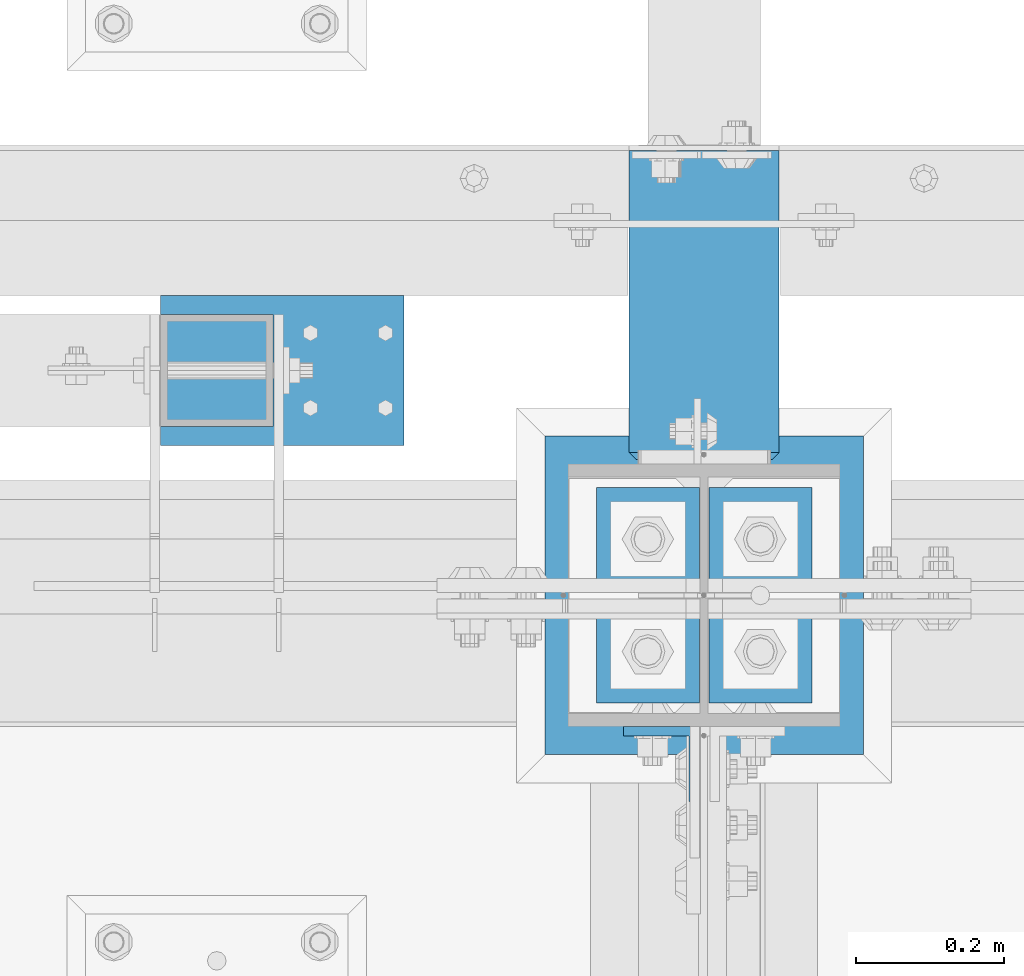
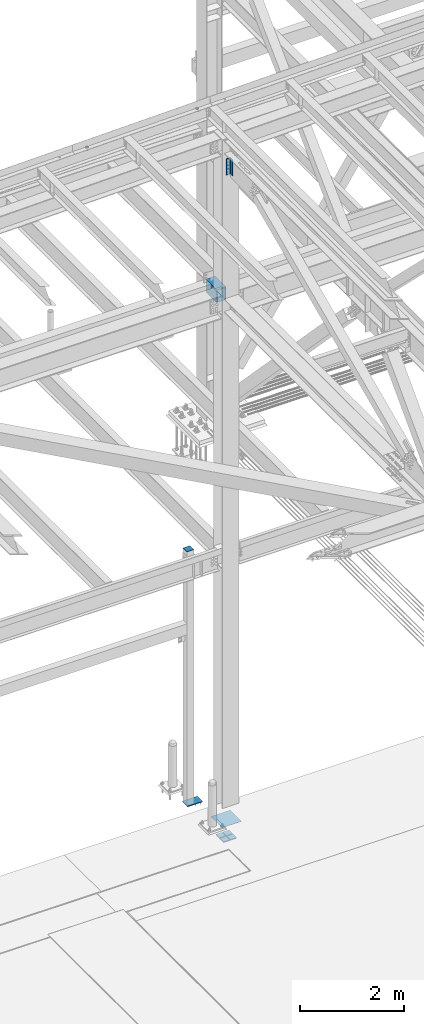
# One storey, part 2544 of 3843: 9 beams, 4 elements without a shape of their own.
"""IFC2X3 building model written with IfcOpenShell, lengths in millimetres."""

from ifc_helpers import new_model, si_unit, frame, origin_with_axes, place, context, subcontext, project, spatial, faceted_brep, material, type_object, element, aggregate, save


model = new_model("IFC2X3")

# Units and contexts
model_context = context("Model", 3, precision=1e-05, world=origin_with_axes())
body_context = subcontext(model_context, "Body", "Model", "MODEL_VIEW")
ifc_project = project(units=[si_unit("LENGTHUNIT", "METRE", prefix="MILLI"), si_unit("AREAUNIT", "SQUARE_METRE"), si_unit("VOLUMEUNIT", "CUBIC_METRE"), si_unit("MASSUNIT", "GRAM", prefix="KILO"), si_unit("TIMEUNIT", "SECOND"), si_unit("PLANEANGLEUNIT", "RADIAN"), si_unit("SOLIDANGLEUNIT", "STERADIAN"), si_unit("THERMODYNAMICTEMPERATUREUNIT", "DEGREE_CELSIUS"), si_unit("LUMINOUSINTENSITYUNIT", "LUMEN")], contexts=[model_context])

# Site, building, storey
site_placement = place(None, origin_with_axes())
site = spatial("IfcSite", under=ifc_project, at=site_placement, CompositionType="ELEMENT")
building_placement = place(site_placement, origin_with_axes())
building = spatial("IfcBuilding", under=site, at=building_placement, Name="Undefined", CompositionType="ELEMENT")
storey_placement = place(building_placement, origin_with_axes())
storey = spatial("IfcBuildingStorey", under=building, at=storey_placement, Name="Undefined", CompositionType="ELEMENT", Elevation=0.0)

# Assembly, beam
assembly_1_placement = place(storey_placement, origin_with_axes())
assembly_1 = element("IfcElementAssembly", 1, at=assembly_1_placement, inside=storey, Name="PLATE", AssemblyPlace="NOTDEFINED", PredefinedType="RIGID_FRAME")
ifc_material_1 = material(Name="STEEL/A572-50")
beam_type_1 = type_object("IfcBeamType", Name="L4X4X1/2", PredefinedType="NOTDEFINED")
beam_1_placement = place(assembly_1_placement, frame((70197.6625, 91986.0999999455, 45662.9621203218), z_axis=(0.0, -1.0, 0.0), x_axis=(0.0, 0.0, -1.0)))
beam_1 = element("IfcBeam", 2, at=beam_1_placement, type_object=beam_type_1, material=ifc_material_1, Name="ANGLE", ObjectType="L4X4X1/2", context=body_context, shape_type="Brep", body=[
    faceted_brep([(0.0, 50.8000000000029, -50.8000000000029), (0.0, 50.8000000000029, 50.8000000000029), (381.0, 50.8000000000029, 50.8000000000029), (381.0, 50.8000000000029, -50.8000000000029), (0.0, 38.0999999999985, 50.8000000000029), (381.0, 38.0999999999985, 50.8000000000029), (0.0, 38.0999999999985, -38.0999999999985), (381.0, 38.0999999999985, -38.1000000000058), (0.0, -50.8000000000029, -38.1000000000058), (381.0, -50.8000000000029, -38.1000000000058), (0.0, -50.8000000000029, -50.8000000000029), (381.0, -50.8000000000029, -50.8000000000029)], [[[0, 1, 2, 3]], [[1, 4, 5, 2]], [[4, 6, 7, 5]], [[6, 8, 9, 7]], [[8, 10, 11, 9]], [[10, 0, 3, 11]], [[5, 7, 9, 11, 3, 2]], [[10, 8, 6, 4, 1, 0]]]),
])
aggregate(assembly_1, [beam_1])

assembly_2_placement = place(storey_placement, origin_with_axes())
assembly_2 = element("IfcElementAssembly", 3, at=assembly_2_placement, inside=storey, Name="POST", AssemblyPlace="NOTDEFINED", PredefinedType="RIGID_FRAME")
beam_type_2 = type_object("IfcBeamType", PredefinedType="NOTDEFINED")
beam_2_placement = place(assembly_2_placement, frame((69596.0, 92443.3, 36433.125), z_axis=(1.0, 0.0, 0.0), x_axis=(0.0, 1.0, 0.0)))
beam_2 = element("IfcBeam", 4, at=beam_2_placement, type_object=beam_type_2, material=ifc_material_1, Name="PLATE", context=body_context, shape_type="Brep", body=[
    faceted_brep([(0.0, 3.17500000000291, -76.2000000000007), (0.0, 3.17499999999927, 76.1999969482422), (152.399999999994, 3.17500000000291, 76.1999999999971), (152.399999999994, 3.17500000000291, -76.1999999999971), (0.0, -3.17499999999927, 76.1999969482422), (152.399999999994, -3.17500000000291, 76.1999999999971), (0.0, -3.17500000000291, -76.2000000000007), (152.399999999994, -3.17500000000291, -76.1999999999971)], [[[0, 1, 2, 3]], [[1, 4, 5, 2]], [[4, 6, 7, 5]], [[6, 0, 3, 7]], [[5, 7, 3, 2]], [[6, 4, 1, 0]]]),
])

assembly_3_placement = place(storey_placement, origin_with_axes())
assembly_3 = element("IfcElementAssembly", 5, at=assembly_3_placement, inside=storey, Name="COLUMN", AssemblyPlace="NOTDEFINED", PredefinedType="RIGID_FRAME")
ifc_material_2 = material()
beam_type_3 = type_object("IfcBeamType", Name="HSS12X8X3/8", PredefinedType="NOTDEFINED")
beam_3_placement = place(assembly_3_placement, frame((70256.4, 92392.5, 42214.8), z_axis=(0.0, 0.0, 1.0), x_axis=(0.0, 1.0, 0.0)))
beam_3 = element("IfcBeam", 6, at=beam_3_placement, type_object=beam_type_3, material=ifc_material_2, Name="GIRT", ObjectType="HSS12X8X3/8", context=body_context, shape_type="Brep", body=[
    faceted_brep([(15.8750001309381, 101.600000000006, 152.399999999972), (15.8749984899478, 101.600000000006, -152.400000000031), (6.35000000002037, 92.0749999999971, -142.875), (6.35000000002037, 92.0749999999971, 142.875), (15.8749984899478, -101.600000000006, -152.400000000031), (6.35000000002037, -92.0749999999971, -142.875), (15.8750001044536, -101.600000052975, 152.399999973481), (6.35000000002037, -92.0749999999971, 142.875), (425.449999999983, -101.600000000006, 152.400000000001), (425.449999999983, 101.600000000006, 152.400000000001), (425.449999999983, -101.600000000006, -152.400000000001), (425.449999999983, 101.600000000006, -152.400000000001), (425.449999999957, -92.074999999968, 142.874999999971), (425.450000000015, 92.0749999999971, 142.875), (425.450000000015, 92.0749999999971, -142.875), (425.450000000015, -92.0749999999971, -142.875)], [[[0, 1, 2, 3]], [[4, 5, 2, 1]], [[6, 7, 5, 4]], [[8, 9, 0, 6]], [[10, 8, 6, 4]], [[11, 10, 4, 1]], [[9, 11, 1, 0]], [[8, 10, 11, 9], [12, 13, 14, 15]], [[3, 2, 14, 13]], [[2, 5, 15, 14]], [[5, 7, 12, 15]], [[7, 3, 13, 12]], [[0, 3, 7, 6]]]),
])
aggregate(assembly_3, [beam_3])

# Beam
beam_type_4 = type_object("IfcBeamType", PredefinedType="NOTDEFINED")
beam_4_placement = place(assembly_2_placement, frame((69684.9000015259, 92417.9000003815, 30486.35), z_axis=(-1.0, 0.0, 0.0), x_axis=(0.0, 1.0, 0.0)))
beam_4 = element("IfcBeam", 7, at=beam_4_placement, type_object=beam_type_4, material=ifc_material_1, context=body_context, shape_type="Brep", body=[
    faceted_brep([(-4.07453626394272e-10, 6.34999999999854, -165.099999999366), (3.92901711165905e-10, 6.34999999999854, 165.099999999351), (203.199999237055, 6.34999999999854, 165.099999999999), (203.199999237055, 6.34999999999854, -165.099999999999), (3.92901711165905e-10, -6.34999999999854, 165.099999999351), (203.199999237055, -6.34999999999854, 165.099999999999), (-4.07453626394272e-10, -6.34999999999854, -165.099999999366), (203.199999237055, -6.34999999999854, -165.099999999999)], [[[0, 1, 2, 3]], [[1, 4, 5, 2]], [[4, 6, 7, 5]], [[6, 0, 3, 7]], [[5, 7, 3, 2]], [[6, 4, 1, 0]]]),
])

aggregate(assembly_2, [beam_2, beam_4])

# Assembly, beams
assembly_4_placement = place(storey_placement, origin_with_axes())
assembly_4 = element("IfcElementAssembly", 8, at=assembly_4_placement, inside=storey, Name="TEMPLATE", AssemblyPlace="NOTDEFINED", PredefinedType="RIGID_FRAME")
beam_type_5 = type_object("IfcBeamType", PredefinedType="NOTDEFINED")
beam_5_placement = place(assembly_4_placement, frame((70180.2, 92068.65, 29656.0875), z_axis=(1.0, 0.0, 0.0), x_axis=(0.0, 1.0, 0.0)))
beam_5 = element("IfcBeam", 9, at=beam_5_placement, type_object=beam_type_5, material=ifc_material_1, context=body_context, shape_type="Brep", body=[
    faceted_brep([(0.0, 11.1124999999993, -69.8499999999985), (0.0, 11.1124999999993, 69.8499999999985), (139.699999999997, 11.1124999999993, 69.8499999999985), (139.699999999997, 11.1124999999993, -69.8499999999985), (0.0, -11.1124999999993, 69.8499999999985), (139.699999999997, -11.1124999999993, 69.8499999999985), (0.0, -11.1124999999993, -69.8499999999985), (139.699999999997, -11.1124999999993, -69.8499999999985)], [[[0, 1, 2, 3]], [[1, 4, 5, 2]], [[4, 6, 7, 5]], [[6, 0, 3, 7]], [[5, 7, 3, 2]], [[6, 4, 1, 0]]]),
])
beam_6_placement = place(assembly_4_placement, frame((70332.6, 92068.65, 29656.0875), z_axis=(1.0, 0.0, 0.0), x_axis=(0.0, 1.0, 0.0)))
beam_6 = element("IfcBeam", 10, at=beam_6_placement, type_object=beam_type_5, material=ifc_material_1, context=body_context, shape_type="Brep", body=[
    faceted_brep([(0.0, 11.1124999999993, -69.8499999999985), (0.0, 11.1124999999993, 69.8499999999985), (139.699999999997, 11.1124999999993, 69.8499999999985), (139.699999999997, 11.1124999999993, -69.8499999999985), (0.0, -11.1124999999993, 69.8499999999985), (139.699999999997, -11.1124999999993, 69.8499999999985), (0.0, -11.1124999999993, -69.8499999999985), (139.699999999997, -11.1124999999993, -69.8499999999985)], [[[0, 1, 2, 3]], [[1, 4, 5, 2]], [[4, 6, 7, 5]], [[6, 0, 3, 7]], [[5, 7, 3, 2]], [[6, 4, 1, 0]]]),
])
beam_7_placement = place(assembly_4_placement, frame((70180.2, 92221.05, 29656.0875), z_axis=(1.0, 0.0, 0.0), x_axis=(0.0, 1.0, 0.0)))
beam_7 = element("IfcBeam", 11, at=beam_7_placement, type_object=beam_type_5, material=ifc_material_1, context=body_context, shape_type="Brep", body=[
    faceted_brep([(0.0, 11.1124999999993, -69.8499999999985), (0.0, 11.1124999999993, 69.8499999999985), (139.699999999997, 11.1124999999993, 69.8499999999985), (139.699999999997, 11.1124999999993, -69.8499999999985), (0.0, -11.1124999999993, 69.8499999999985), (139.699999999997, -11.1124999999993, 69.8499999999985), (0.0, -11.1124999999993, -69.8499999999985), (139.699999999997, -11.1124999999993, -69.8499999999985)], [[[0, 1, 2, 3]], [[1, 4, 5, 2]], [[4, 6, 7, 5]], [[6, 0, 3, 7]], [[5, 7, 3, 2]], [[6, 4, 1, 0]]]),
])
beam_8_placement = place(assembly_4_placement, frame((70332.6, 92221.05, 29656.0875), z_axis=(1.0, 0.0, 0.0), x_axis=(0.0, 1.0, 0.0)))
beam_8 = element("IfcBeam", 12, at=beam_8_placement, type_object=beam_type_5, material=ifc_material_1, context=body_context, shape_type="Brep", body=[
    faceted_brep([(0.0, 11.1124999999993, -69.8499999999985), (0.0, 11.1124999999993, 69.8499999999985), (139.699999999997, 11.1124999999993, 69.8499999999985), (139.699999999997, 11.1124999999993, -69.8499999999985), (0.0, -11.1124999999993, 69.8499999999985), (139.699999999997, -11.1124999999993, 69.8499999999985), (0.0, -11.1124999999993, -69.8499999999985), (139.699999999997, -11.1124999999993, -69.8499999999985)], [[[0, 1, 2, 3]], [[1, 4, 5, 2]], [[4, 6, 7, 5]], [[6, 0, 3, 7]], [[5, 7, 3, 2]], [[6, 4, 1, 0]]]),
])
beam_type_6 = type_object("IfcBeamType", PredefinedType="NOTDEFINED")
beam_9_placement = place(assembly_4_placement, frame((70256.4, 91998.8000015259, 30064.075), z_axis=(-1.0, 0.0, 0.0), x_axis=(0.0, 1.0, 0.0)))
beam_9 = element("IfcBeam", 13, at=beam_9_placement, type_object=beam_type_6, material=ifc_material_1, Name="TEMPLATE", context=body_context, shape_type="Brep", body=[
    faceted_brep([(0.0, 3.17499999999927, -215.900000000001), (0.0, 3.17499999999927, 215.900000000001), (431.799999999988, 3.17499999999927, 215.900000000001), (431.799999999988, 3.17499999999927, -215.900000000001), (0.0, -3.17499999999927, 215.900000000001), (431.799999999988, -3.17499999999927, 215.900000000001), (0.0, -3.17499999999927, -215.900000000001), (431.799999999988, -3.17499999999927, -215.900000000001)], [[[0, 1, 2, 3]], [[1, 4, 5, 2]], [[4, 6, 7, 5]], [[6, 0, 3, 7]], [[5, 7, 3, 2]], [[6, 4, 1, 0]]]),
])
aggregate(assembly_4, [beam_5, beam_6, beam_7, beam_8, beam_9])

save(model, "model.ifc")
